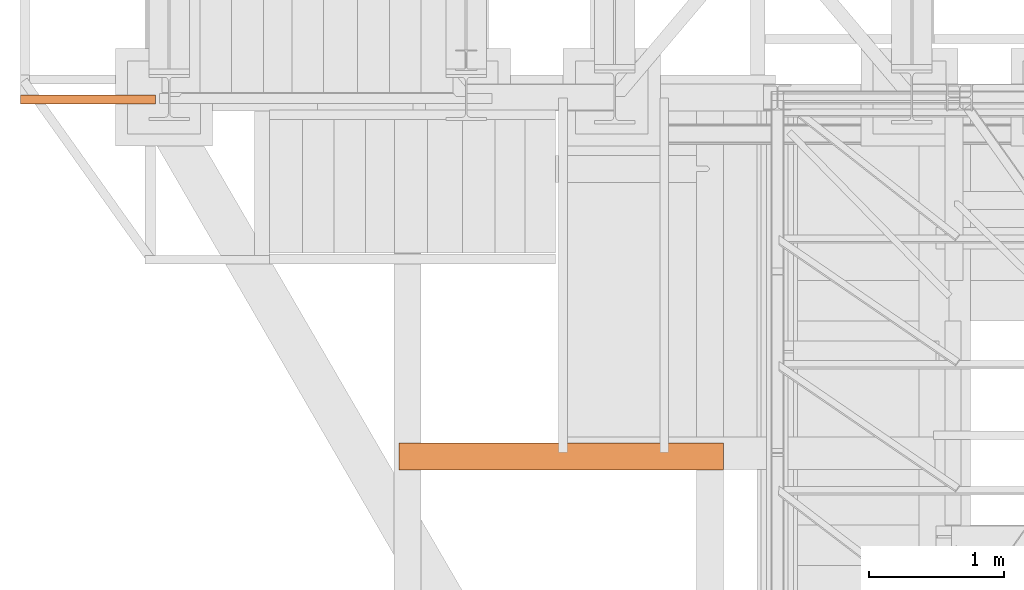
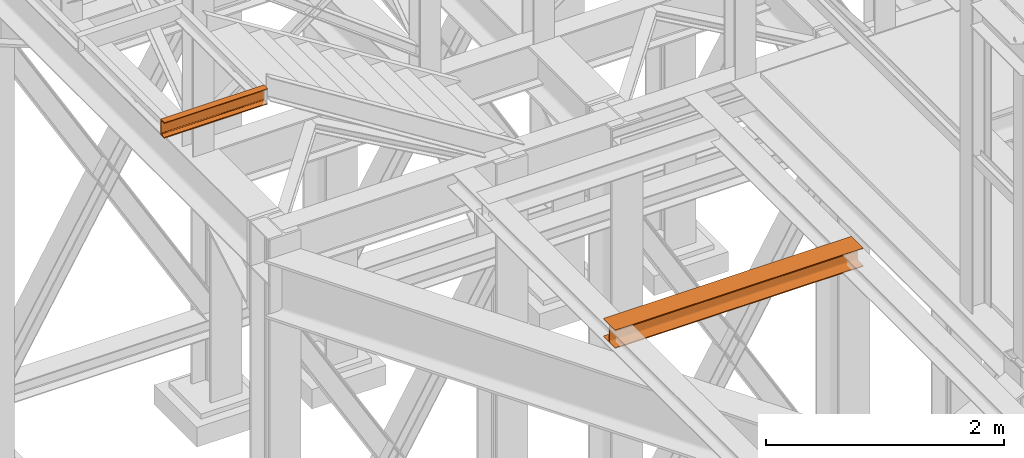
# One storey, part 17 of 208: 2 proxies.
"""IFC2X3 building model written with IfcOpenShell, lengths in millimetres."""

from ifc_helpers import new_model, entity, si_unit, converted_unit, frame, origin, origin_with_axes, place, context, subcontext, project, spatial, faceted_brep, element, save


model = new_model("IFC2X3")

# Units and contexts
model_context = context("Model", 3, precision=1e-05, world=origin())
plan_context = context("Plan", 3, precision=1e-05, world=origin())
body_context = subcontext(model_context, "Body", "Model", "MODEL_VIEW")
ifc_project = project(units=[si_unit("LENGTHUNIT", "METRE", prefix="MILLI"), converted_unit("PLANEANGLEUNIT", "DEGREE", entity("IfcPlaneAngleMeasure", 0.0174532925199433), si_unit("PLANEANGLEUNIT", "RADIAN"), dimensions=[0, 0, 0, 0, 0, 0, 0]), si_unit("AREAUNIT", "SQUARE_METRE"), si_unit("VOLUMEUNIT", "CUBIC_METRE")], contexts=[model_context, plan_context])

# Building, storey
building_placement = place(None, origin())
building = spatial("IfcBuilding", under=ifc_project, at=building_placement, CompositionType="COMPLEX")
storey_placement = place(building_placement, origin_with_axes())
storey = spatial("IfcBuildingStorey", under=building, at=storey_placement, Name="Geschoss", CompositionType="ELEMENT")

# Proxies
proxy_1_placement = place(storey_placement, frame((-1605.876075509834, -20022.50386180536, 5094.990005364416), z_axis=(0.0, 0.0, 1.0), x_axis=(1.0, 0.0, 0.0)))
element("IfcBuildingElementProxy", 1, at=proxy_1_placement, inside=storey, context=body_context, shape_type="Brep", body=[
    faceted_brep([(0.01000000000362888, 200.0099999999984, 0.01000000000021828), (2404.141044038497, 200.0099999999984, 0.01000000000021828), (2404.141044038497, 200.0099999999984, 10.01000000000022), (0.01000000000362888, 200.0099999999984, 10.01000000000022), (0.01000000000362888, 200.0099999999984, 10.01000000000022), (2404.141044038497, 200.0099999999984, 10.01000000000022), (2404.141044038497, 121.2599999999984, 10.01000000000022), (0.01000000000362888, 121.2599999999984, 10.01000000000022), (0.01000000000362888, 121.2599999999984, 10.01000000000022), (2404.141044038497, 121.2599999999984, 10.01000000000022), (2404.141044038497, 115.6977129694242, 10.89104403849342), (0.01000000000362888, 115.6977129694242, 10.89104403849342), (0.01000000000362888, 115.6977129694242, 10.89104403849342), (2404.141044038497, 115.6977129694242, 10.89104403849342), (2404.141044038497, 110.6798832894638, 13.44771635773213), (0.01000000000362888, 110.6798832894638, 13.44771635773213), (0.01000000000362888, 110.6798832894638, 13.44771635773213), (2404.141044038497, 110.6798832894638, 13.44771635773213), (2404.141044038496, 106.6977163577321, 17.42988328946558), (0.01000000000180989, 106.6977163577321, 17.42988328946558), (0.01000000000180989, 106.6977163577321, 17.42988328946558), (2404.141044038496, 106.6977163577321, 17.42988328946558), (2404.141044038497, 104.1410440384934, 22.44771296942599), (0.01000000000180989, 104.1410440384934, 22.44771296942599), (0.01000000000180989, 104.1410440384934, 22.44771296942599), (2404.141044038497, 104.1410440384934, 22.44771296942599), (2404.141044038497, 103.2599999999984, 28.01000000000022), (0.01000000000362888, 103.2599999999984, 28.01000000000022), (0.01000000000362888, 103.2599999999984, 28.01000000000022), (2404.141044038497, 103.2599999999984, 28.01000000000022), (2404.141044038496, 103.2599999999984, 162.0100000000002), (0.01000000000180989, 103.2599999999984, 162.0100000000002), (0.01000000000180989, 103.2599999999984, 162.0100000000002), (2404.141044038496, 103.2599999999984, 162.0100000000002), (2404.141044038497, 104.1410440384934, 167.5722870305744), (0.01000000000362888, 104.1410440384934, 167.5722870305744), (0.01000000000362888, 104.1410440384934, 167.5722870305744), (2404.141044038497, 104.1410440384934, 167.5722870305744), (2404.141044038497, 106.6977163577321, 172.5901167105349), (0.01000000000362888, 106.6977163577321, 172.5901167105349), (0.01000000000362888, 106.6977163577321, 172.5901167105349), (2404.141044038497, 106.6977163577321, 172.5901167105349), (2404.141044038497, 110.6798832894638, 176.5722836422683), (0.009999999999990905, 110.6798832894638, 176.5722836422683), (0.009999999999990905, 110.6798832894638, 176.5722836422683), (2404.141044038497, 110.6798832894638, 176.5722836422683), (2404.141044038497, 115.6977129694242, 179.128955961507), (0.01000000000362888, 115.6977129694242, 179.128955961507), (0.01000000000362888, 115.6977129694242, 179.128955961507), (2404.141044038497, 115.6977129694242, 179.128955961507), (2404.141044038497, 120.0099999999984, 180.0100000000002), (0.01000000000362888, 120.0099999999984, 180.0100000000002), (0.01000000000362888, 120.0099999999984, 180.0100000000002), (2404.141044038497, 120.0099999999984, 180.0100000000002), (2404.141044038497, 200.0099999999984, 180.0100000000002), (0.01000000000362888, 200.0099999999984, 180.0100000000002), (0.01000000000362888, 200.0099999999984, 180.0100000000002), (2404.141044038497, 200.0099999999984, 180.0100000000002), (2404.141044038497, 200.0099999999984, 190.0100000000002), (0.01000000000362888, 200.0099999999984, 190.0100000000002), (0.01000000000362888, 200.0099999999984, 190.0100000000002), (2404.141044038497, 200.0099999999984, 190.0100000000002), (2404.141044038497, 0.00999999999839929, 190.0100000000002), (0.01000000000362888, 0.00999999999839929, 190.0100000000002), (0.01000000000362888, 0.00999999999839929, 190.0100000000002), (2404.141044038497, 0.00999999999839929, 190.0100000000002), (2404.141044038497, 0.00999999999839929, 180.0100000000002), (0.01000000000362888, 0.00999999999839929, 180.0100000000002), (0.01000000000362888, 0.00999999999839929, 180.0100000000002), (2404.141044038497, 0.00999999999839929, 180.0100000000002), (2404.141044038497, 78.7599999999984, 180.0100000000002), (0.01000000000362888, 78.7599999999984, 180.0100000000002), (0.01000000000362888, 78.7599999999984, 180.0100000000002), (2404.141044038497, 78.7599999999984, 180.0100000000002), (2404.141044038498, 84.32228703057262, 179.1289559615061), (0.01000000000180989, 84.32228703057262, 179.128955961507), (0.01000000000180989, 84.32228703057262, 179.128955961507), (2404.141044038498, 84.32228703057262, 179.1289559615061), (2404.141044038498, 89.34011671053304, 176.5722836422674), (0.01000000000362888, 89.34011671053304, 176.5722836422683), (0.01000000000362888, 89.34011671053304, 176.5722836422683), (2404.141044038498, 89.34011671053304, 176.5722836422674), (2404.141044038497, 93.3222836422683, 172.5901167105349), (0.01000000000362888, 93.3222836422683, 172.5901167105349), (0.01000000000362888, 93.3222836422683, 172.5901167105349), (2404.141044038497, 93.3222836422683, 172.5901167105349), (2404.141044038496, 95.87895596150338, 167.5722870305744), (0.01000000000180989, 95.87895596150338, 167.5722870305744), (0.01000000000180989, 95.87895596150338, 167.5722870305744), (2404.141044038496, 95.87895596150338, 167.5722870305744), (2404.141044038497, 96.7599999999984, 162.0100000000002), (0.01000000000362888, 96.7599999999984, 162.0100000000002), (0.01000000000362888, 96.7599999999984, 162.0100000000002), (2404.141044038497, 96.7599999999984, 162.0100000000002), (2404.141044038498, 96.7599999999984, 28.01000000000022), (0.01000000000180989, 96.7599999999984, 28.01000000000022), (0.01000000000180989, 96.7599999999984, 28.01000000000022), (2404.141044038498, 96.7599999999984, 28.01000000000022), (2404.141044038498, 95.87895596150338, 22.44771296942508), (0.01000000000180989, 95.87895596150338, 22.44771296942599), (0.01000000000180989, 95.87895596150338, 22.44771296942599), (2404.141044038498, 95.87895596150338, 22.44771296942508), (2404.141044038497, 93.3222836422683, 17.42988328946558), (0.01000000000362888, 93.3222836422683, 17.42988328946558), (0.01000000000362888, 93.3222836422683, 17.42988328946558), (2404.141044038497, 93.3222836422683, 17.42988328946558), (2404.141044038496, 89.34011671053304, 13.44771635773213), (0.01000000000180989, 89.34011671053304, 13.44771635773213), (0.01000000000180989, 89.34011671053304, 13.44771635773213), (2404.141044038496, 89.34011671053304, 13.44771635773213), (2404.141044038497, 84.32228703057262, 10.89104403849342), (0.01000000000362888, 84.32228703057262, 10.89104403849342), (0.01000000000362888, 84.32228703057262, 10.89104403849342), (2404.141044038497, 84.32228703057262, 10.89104403849342), (2404.141044038496, 78.7599999999984, 10.01000000000022), (0.01000000000180989, 78.7599999999984, 10.01000000000022), (0.01000000000180989, 78.7599999999984, 10.01000000000022), (2404.141044038496, 78.7599999999984, 10.01000000000022), (2404.141044038497, 0.00999999999839929, 10.01000000000022), (0.01000000000362888, 0.00999999999839929, 10.01000000000022), (0.01000000000362888, 0.00999999999839929, 10.01000000000022), (2404.141044038497, 0.00999999999839929, 10.01000000000022), (2404.141044038498, 0.00999999999839929, 0.01000000000021828), (0.01000000000180989, 0.00999999999839929, 0.01000000000021828), (0.01000000000180989, 0.00999999999839929, 0.01000000000021828), (2404.141044038498, 0.00999999999839929, 0.01000000000021828), (2404.141044038497, 200.0099999999984, 0.01000000000021828), (0.01000000000362888, 200.0099999999984, 0.01000000000021828), (2404.141044038497, 200.0099999999984, 0.01000000000021828), (2404.141044038498, 0.00999999999839929, 0.01000000000021828), (2404.141044038497, 0.00999999999839929, 10.01000000000022), (2404.141044038496, 78.7599999999984, 10.01000000000022), (2404.141044038497, 84.32228703057262, 10.89104403849342), (2404.141044038496, 89.34011671053304, 13.44771635773213), (2404.141044038497, 93.3222836422683, 17.42988328946558), (2404.141044038498, 95.87895596150338, 22.44771296942508), (2404.141044038498, 96.7599999999984, 28.01000000000022), (2404.141044038497, 96.7599999999984, 162.0100000000002), (2404.141044038496, 95.87895596150338, 167.5722870305744), (2404.141044038497, 93.3222836422683, 172.5901167105349), (2404.141044038498, 89.34011671053304, 176.5722836422674), (2404.141044038498, 84.32228703057262, 179.1289559615061), (2404.141044038497, 78.7599999999984, 180.0100000000002), (2404.141044038497, 0.00999999999839929, 180.0100000000002), (2404.141044038497, 0.00999999999839929, 190.0100000000002), (2404.141044038497, 200.0099999999984, 190.0100000000002), (2404.141044038497, 200.0099999999984, 180.0100000000002), (2404.141044038497, 120.0099999999984, 180.0100000000002), (2404.141044038497, 115.6977129694242, 179.128955961507), (2404.141044038497, 110.6798832894638, 176.5722836422683), (2404.141044038497, 106.6977163577321, 172.5901167105349), (2404.141044038497, 104.1410440384934, 167.5722870305744), (2404.141044038496, 103.2599999999984, 162.0100000000002), (2404.141044038497, 103.2599999999984, 28.01000000000022), (2404.141044038497, 104.1410440384934, 22.44771296942599), (2404.141044038496, 106.6977163577321, 17.42988328946558), (2404.141044038497, 110.6798832894638, 13.44771635773213), (2404.141044038497, 115.6977129694242, 10.89104403849342), (2404.141044038497, 121.2599999999984, 10.01000000000022), (2404.141044038497, 200.0099999999984, 10.01000000000022), (0.01000000000362888, 200.0099999999984, 10.01000000000022), (0.01000000000362888, 121.2599999999984, 10.01000000000022), (0.01000000000362888, 115.6977129694242, 10.89104403849342), (0.01000000000362888, 110.6798832894638, 13.44771635773213), (0.01000000000180989, 106.6977163577321, 17.42988328946558), (0.01000000000180989, 104.1410440384934, 22.44771296942599), (0.01000000000362888, 103.2599999999984, 28.01000000000022), (0.01000000000180989, 103.2599999999984, 162.0100000000002), (0.01000000000362888, 104.1410440384934, 167.5722870305744), (0.01000000000362888, 106.6977163577321, 172.5901167105349), (0.009999999999990905, 110.6798832894638, 176.5722836422683), (0.01000000000362888, 115.6977129694242, 179.128955961507), (0.01000000000362888, 120.0099999999984, 180.0100000000002), (0.01000000000362888, 200.0099999999984, 180.0100000000002), (0.01000000000362888, 200.0099999999984, 190.0100000000002), (0.01000000000362888, 0.00999999999839929, 190.0100000000002), (0.01000000000362888, 0.00999999999839929, 180.0100000000002), (0.01000000000362888, 78.7599999999984, 180.0100000000002), (0.01000000000180989, 84.32228703057262, 179.128955961507), (0.01000000000362888, 89.34011671053304, 176.5722836422683), (0.01000000000362888, 93.3222836422683, 172.5901167105349), (0.01000000000180989, 95.87895596150338, 167.5722870305744), (0.01000000000362888, 96.7599999999984, 162.0100000000002), (0.01000000000180989, 96.7599999999984, 28.01000000000022), (0.01000000000180989, 95.87895596150338, 22.44771296942599), (0.01000000000362888, 93.3222836422683, 17.42988328946558), (0.01000000000180989, 89.34011671053304, 13.44771635773213), (0.01000000000362888, 84.32228703057262, 10.89104403849342), (0.01000000000180989, 78.7599999999984, 10.01000000000022), (0.01000000000362888, 0.00999999999839929, 10.01000000000022), (0.01000000000180989, 0.00999999999839929, 0.01000000000021828), (0.01000000000362888, 200.0099999999984, 0.01000000000021828)], [[[0, 1, 2, 3]], [[4, 5, 6, 7]], [[8, 9, 10, 11]], [[12, 13, 14, 15]], [[16, 17, 18, 19]], [[20, 21, 22, 23]], [[24, 25, 26, 27]], [[28, 29, 30, 31]], [[32, 33, 34, 35]], [[36, 37, 38, 39]], [[40, 41, 42, 43]], [[44, 45, 46, 47]], [[48, 49, 50, 51]], [[52, 53, 54, 55]], [[56, 57, 58, 59]], [[60, 61, 62, 63]], [[64, 65, 66, 67]], [[68, 69, 70, 71]], [[72, 73, 74, 75]], [[76, 77, 78, 79]], [[80, 81, 82, 83]], [[84, 85, 86, 87]], [[88, 89, 90, 91]], [[92, 93, 94, 95]], [[96, 97, 98, 99]], [[100, 101, 102, 103]], [[104, 105, 106, 107]], [[108, 109, 110, 111]], [[112, 113, 114, 115]], [[116, 117, 118, 119]], [[120, 121, 122, 123]], [[124, 125, 126, 127]], [[128, 129, 130, 131, 132, 133, 134, 135, 136, 137, 138, 139, 140, 141, 142, 143, 144, 145, 146, 147, 148, 149, 150, 151, 152, 153, 154, 155, 156, 157, 158, 159]], [[160, 161, 162, 163, 164, 165, 166, 167, 168, 169, 170, 171, 172, 173, 174, 175, 176, 177, 178, 179, 180, 181, 182, 183, 184, 185, 186, 187, 188, 189, 190, 191]]], orient=[[False], [False], [False], [False], [False], [False], [False], [False], [False], [False], [False], [False], [False], [False], [False], [False], [False], [False], [False], [False], [False], [False], [False], [False], [False], [False], [False], [False], [False], [False], [False], [False], [False], [False]]),
])
proxy_2_placement = place(storey_placement, frame((-4406.745032961459, -17310.41171836148, 6584.990005364416), z_axis=(0.0, 0.0, 1.0), x_axis=(1.0, 0.0, 0.0)))
element("IfcBuildingElementProxy", 2, at=proxy_2_placement, inside=storey, context=body_context, shape_type="Brep", body=[
    faceted_brep([(0.01000000000021828, 0.00999999999839929, 0.01000000000021828), (0.01000000000021828, 0.00999999999839929, 3.132428070246533), (1000.010000000006, 0.00999999999839929, 3.132428070246533), (1000.010000000006, 0.00999999999839929, 0.01000000000021828), (0.01000000000021828, 0.00999999999839929, 3.132428070246533), (0.01000000000021828, 0.2527365771711629, 4.748288908171162), (1000.010000000006, 0.2527365771711629, 4.748288908171162), (1000.010000000006, 0.00999999999839929, 3.132428070246533), (0.01000000000021828, 0.2527365771711629, 4.748288908171162), (0.01000000000021828, 0.9594677141431021, 6.221534443444398), (1000.010000000006, 0.9594677141431021, 6.221534443444398), (1000.010000000006, 0.2527365771711629, 4.748288908171162), (0.01000000000021828, 0.9594677141431021, 6.221534443444398), (0.01000000000021828, 2.067848361530196, 7.422126703873801), (1000.010000000006, 2.067848361530196, 7.422126703873801), (1000.010000000006, 0.9594677141431021, 6.221534443444398), (0.01000000000021828, 2.067848361530196, 7.422126703873801), (0.01000000000021828, 3.4800435885154, 8.244091391710754), (1000.010000000006, 3.480043588511762, 8.244091391710754), (1000.010000000006, 2.067848361530196, 7.422126703873801), (0.01000000000021828, 3.4800435885154, 8.244091391710754), (0.01000000000021828, 5.071401277444238, 8.614912102195376), (1000.010000000006, 5.0714012774406, 8.614912102195376), (1000.010000000006, 3.480043588511762, 8.244091391710754), (0.01000000000021828, 5.071401277444238, 8.614912102195376), (0.01000000000021828, 47.84732483396874, 12.0369859867169), (1000.010000000006, 47.84732483396874, 12.0369859867169), (1000.010000000006, 5.0714012774406, 8.614912102195376), (0.01000000000021828, 47.84732483396874, 12.0369859867169), (0.01000000000021828, 50.88537133101636, 12.74491643400506), (1000.010000000006, 50.88537133101272, 12.74491643400506), (1000.010000000006, 47.84732483396874, 12.0369859867169), (0.01000000000021828, 50.88537133101636, 12.74491643400506), (0.01000000000021828, 53.58138040071208, 14.31412174714933), (1000.010000000006, 53.58138040071208, 14.31412174714933), (1000.010000000006, 50.88537133101272, 12.74491643400506), (0.01000000000021828, 53.58138040071208, 14.31412174714933), (0.01000000000021828, 55.69737981845174, 16.60616151705835), (1000.010000000006, 55.69737981845174, 16.60616151705835), (1000.010000000006, 53.58138040071208, 14.31412174714933), (0.01000000000021828, 55.69737981845174, 16.60616151705835), (0.01000000000021828, 57.04659380721205, 19.41872117530875), (1000.010000000006, 57.04659380721205, 19.41872117530875), (1000.010000000006, 55.69737981845174, 16.60616151705835), (0.01000000000021828, 57.04659380721205, 19.41872117530875), (0.01000000000021828, 57.5099999999984, 22.50354641134618), (1000.010000000006, 57.5099999999984, 22.50354641134618), (1000.010000000006, 57.04659380721205, 19.41872117530875), (0.01000000000021828, 57.5099999999984, 22.50354641134618), (0.01000000000021828, 57.5099999999984, 137.5164535886524), (1000.010000000006, 57.5099999999984, 137.5164535886524), (1000.010000000006, 57.5099999999984, 22.50354641134618), (0.01000000000021828, 57.5099999999984, 137.5164535886524), (0.01000000000021828, 57.04659380721205, 140.6012788246917), (1000.010000000006, 57.04659380721205, 140.6012788246917), (1000.010000000006, 57.5099999999984, 137.5164535886524), (0.01000000000021828, 57.04659380721205, 140.6012788246917), (0.01000000000021828, 55.69737981845174, 143.4138384829403), (1000.010000000006, 55.69737981845174, 143.4138384829403), (1000.010000000006, 57.04659380721205, 140.6012788246917), (0.01000000000021828, 55.69737981845174, 143.4138384829403), (0.01000000000021828, 53.58138040071208, 145.7058782528493), (1000.010000000006, 53.58138040071208, 145.7058782528493), (1000.010000000006, 55.69737981845174, 143.4138384829403), (0.01000000000021828, 53.58138040071208, 145.7058782528493), (0.01000000000021828, 50.88537133101636, 147.2750835659936), (1000.010000000006, 50.88537133101272, 147.2750835659936), (1000.010000000006, 53.58138040071208, 145.7058782528493), (0.01000000000021828, 50.88537133101636, 147.2750835659936), (0.01000000000021828, 47.84732483396874, 147.9830140132817), (1000.010000000006, 47.84732483396874, 147.9830140132817), (1000.010000000006, 50.88537133101272, 147.2750835659936), (0.01000000000021828, 47.84732483396874, 147.9830140132817), (0.01000000000021828, 5.071401277444238, 151.4050878978032), (1000.010000000006, 5.0714012774406, 151.4050878978032), (1000.010000000006, 47.84732483396874, 147.9830140132817), (0.01000000000021828, 5.071401277444238, 151.4050878978032), (0.01000000000021828, 3.4800435885154, 151.7759086082879), (1000.010000000006, 3.480043588511762, 151.7759086082879), (1000.010000000006, 5.0714012774406, 151.4050878978032), (0.01000000000021828, 3.4800435885154, 151.7759086082879), (0.01000000000021828, 2.067848361530196, 152.5978732961248), (1000.010000000006, 2.067848361530196, 152.5978732961248), (1000.010000000006, 3.480043588511762, 151.7759086082879), (0.01000000000021828, 2.067848361530196, 152.5978732961248), (0.01000000000021828, 0.9594677141431021, 153.7984655565542), (1000.010000000006, 0.9594677141431021, 153.7984655565542), (1000.010000000006, 2.067848361530196, 152.5978732961248), (0.01000000000021828, 0.9594677141431021, 153.7984655565542), (0.01000000000021828, 0.2527365771711629, 155.2717110918275), (1000.010000000006, 0.2527365771711629, 155.2717110918275), (1000.010000000006, 0.9594677141431021, 153.7984655565542), (0.01000000000021828, 0.2527365771711629, 155.2717110918275), (0.01000000000021828, 0.00999999999839929, 156.8875719297521), (1000.010000000006, 0.00999999999839929, 156.8875719297521), (1000.010000000006, 0.2527365771711629, 155.2717110918275), (0.01000000000021828, 0.00999999999839929, 156.8875719297521), (0.01000000000021828, 0.00999999999839929, 160.0100000000002), (1000.010000000006, 0.00999999999839929, 160.0100000000002), (1000.010000000006, 0.00999999999839929, 156.8875719297521), (0.01000000000021828, 0.00999999999839929, 160.0100000000002), (0.01000000000021828, 65.0099999999984, 160.0100000000002), (1000.010000000006, 65.0099999999984, 160.0100000000002), (1000.010000000006, 0.00999999999839929, 160.0100000000002), (0.01000000000021828, 65.0099999999984, 160.0100000000002), (0.01000000000021828, 65.0099999999984, 0.01000000000021828), (1000.010000000006, 65.0099999999984, 0.01000000000021828), (1000.010000000006, 65.0099999999984, 160.0100000000002), (0.01000000000021828, 65.0099999999984, 0.01000000000021828), (0.01000000000021828, 0.00999999999839929, 0.01000000000021828), (1000.010000000006, 0.00999999999839929, 0.01000000000021828), (1000.010000000006, 65.0099999999984, 0.01000000000021828), (0.01000000000021828, 0.00999999999839929, 0.01000000000021828), (0.01000000000021828, 65.0099999999984, 0.01000000000021828), (0.01000000000021828, 65.0099999999984, 160.0100000000002), (0.01000000000021828, 0.00999999999839929, 160.0100000000002), (0.01000000000021828, 0.00999999999839929, 156.8875719297521), (0.01000000000021828, 0.2527365771711629, 155.2717110918275), (0.01000000000021828, 0.9594677141431021, 153.7984655565542), (0.01000000000021828, 2.067848361530196, 152.5978732961248), (0.01000000000021828, 3.4800435885154, 151.7759086082879), (0.01000000000021828, 5.071401277444238, 151.4050878978032), (0.01000000000021828, 47.84732483396874, 147.9830140132817), (0.01000000000021828, 50.88537133101636, 147.2750835659936), (0.01000000000021828, 53.58138040071208, 145.7058782528493), (0.01000000000021828, 55.69737981845174, 143.4138384829403), (0.01000000000021828, 57.04659380721205, 140.6012788246917), (0.01000000000021828, 57.5099999999984, 137.5164535886524), (0.01000000000021828, 57.5099999999984, 22.50354641134618), (0.01000000000021828, 57.04659380721205, 19.41872117530875), (0.01000000000021828, 55.69737981845174, 16.60616151705835), (0.01000000000021828, 53.58138040071208, 14.31412174714933), (0.01000000000021828, 50.88537133101636, 12.74491643400506), (0.01000000000021828, 47.84732483396874, 12.0369859867169), (0.01000000000021828, 5.071401277444238, 8.614912102195376), (0.01000000000021828, 3.4800435885154, 8.244091391710754), (0.01000000000021828, 2.067848361530196, 7.422126703873801), (0.01000000000021828, 0.9594677141431021, 6.221534443444398), (0.01000000000021828, 0.2527365771711629, 4.748288908171162), (0.01000000000021828, 0.00999999999839929, 3.132428070246533), (1000.010000000006, 0.00999999999839929, 0.01000000000021828), (1000.010000000006, 0.00999999999839929, 3.132428070246533), (1000.010000000006, 0.2527365771711629, 4.748288908171162), (1000.010000000006, 0.9594677141431021, 6.221534443444398), (1000.010000000006, 2.067848361530196, 7.422126703873801), (1000.010000000006, 3.480043588511762, 8.244091391710754), (1000.010000000006, 5.0714012774406, 8.614912102195376), (1000.010000000006, 47.84732483396874, 12.0369859867169), (1000.010000000006, 50.88537133101272, 12.74491643400506), (1000.010000000006, 53.58138040071208, 14.31412174714933), (1000.010000000006, 55.69737981845174, 16.60616151705835), (1000.010000000006, 57.04659380721205, 19.41872117530875), (1000.010000000006, 57.5099999999984, 22.50354641134618), (1000.010000000006, 57.5099999999984, 137.5164535886524), (1000.010000000006, 57.04659380721205, 140.6012788246917), (1000.010000000006, 55.69737981845174, 143.4138384829403), (1000.010000000006, 53.58138040071208, 145.7058782528493), (1000.010000000006, 50.88537133101272, 147.2750835659936), (1000.010000000006, 47.84732483396874, 147.9830140132817), (1000.010000000006, 5.0714012774406, 151.4050878978032), (1000.010000000006, 3.480043588511762, 151.7759086082879), (1000.010000000006, 2.067848361530196, 152.5978732961248), (1000.010000000006, 0.9594677141431021, 153.7984655565542), (1000.010000000006, 0.2527365771711629, 155.2717110918275), (1000.010000000006, 0.00999999999839929, 156.8875719297521), (1000.010000000006, 0.00999999999839929, 160.0100000000002), (1000.010000000006, 65.0099999999984, 160.0100000000002), (1000.010000000006, 65.0099999999984, 0.01000000000021828)], [[[0, 1, 2, 3]], [[4, 5, 6, 7]], [[8, 9, 10, 11]], [[12, 13, 14, 15]], [[16, 17, 18, 19]], [[20, 21, 22, 23]], [[24, 25, 26, 27]], [[28, 29, 30, 31]], [[32, 33, 34, 35]], [[36, 37, 38, 39]], [[40, 41, 42, 43]], [[44, 45, 46, 47]], [[48, 49, 50, 51]], [[52, 53, 54, 55]], [[56, 57, 58, 59]], [[60, 61, 62, 63]], [[64, 65, 66, 67]], [[68, 69, 70, 71]], [[72, 73, 74, 75]], [[76, 77, 78, 79]], [[80, 81, 82, 83]], [[84, 85, 86, 87]], [[88, 89, 90, 91]], [[92, 93, 94, 95]], [[96, 97, 98, 99]], [[100, 101, 102, 103]], [[104, 105, 106, 107]], [[108, 109, 110, 111]], [[112, 113, 114, 115, 116, 117, 118, 119, 120, 121, 122, 123, 124, 125, 126, 127, 128, 129, 130, 131, 132, 133, 134, 135, 136, 137, 138, 139]], [[140, 141, 142, 143, 144, 145, 146, 147, 148, 149, 150, 151, 152, 153, 154, 155, 156, 157, 158, 159, 160, 161, 162, 163, 164, 165, 166, 167]]], orient=[[False], [False], [False], [False], [False], [False], [False], [False], [False], [False], [False], [False], [False], [False], [False], [False], [False], [False], [False], [False], [False], [False], [False], [False], [False], [False], [False], [False], [False], [False]]),
])

save(model, "model.ifc")
